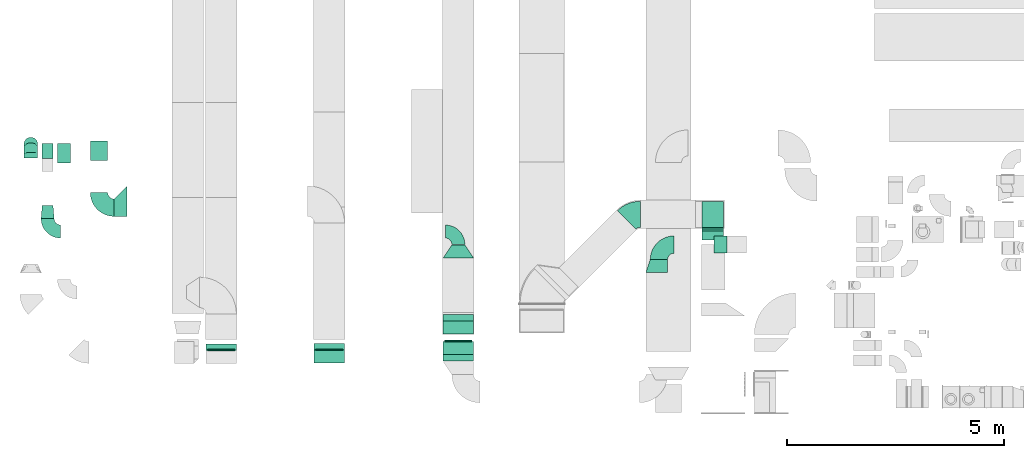
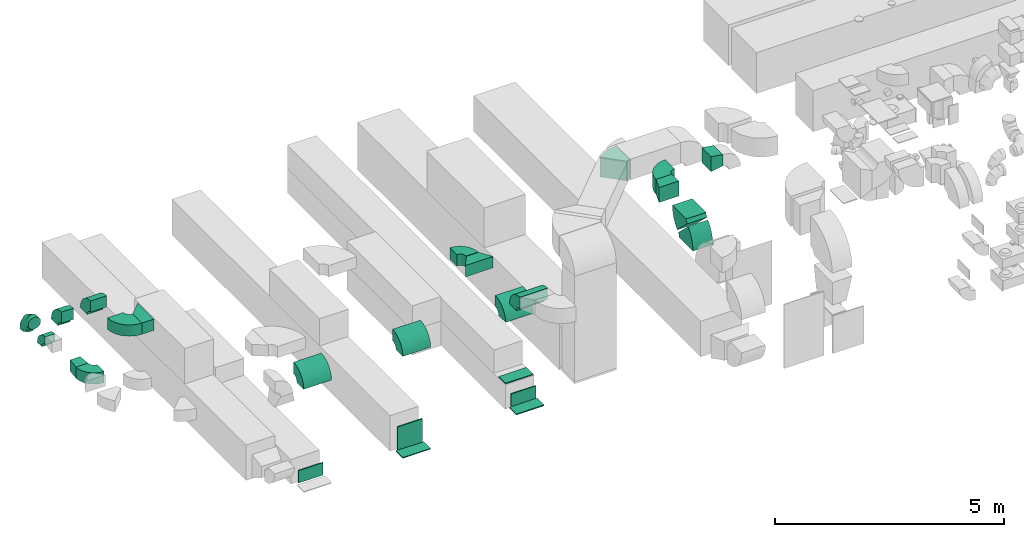
# One storey, part 6 of 59: 26 flow fittings.
"""IFC2X3 building model written with IfcOpenShell, lengths in millimetres."""

import ifcopenshell
import ifcopenshell.guid

model = None  # the IFC model being written
_history = None  # IfcOwnerHistory: only IFC2X3 demands one
_inside = {}  # id of a spatial element -> (the spatial element, [elements in it])
_under = {}  # id of a project, library or spatial element -> (it, [spatial elements below it])
_declared = {}  # id of a project -> (the project, [libraries it declares])
_typed = {}  # id of a type object -> (the type object, [elements of that type])
_made_of = {}  # id of a material, layer set ... -> (it, [elements and type objects made of it])


def new_model(schema):
    """Start an empty IFC model of exactly this schema.

    Asked for "IFC4X3", IfcOpenShell would pick the latest addendum, in which some entities
    have other attributes; the version numbers below select the first issue.
    IFC2X3 requires an IfcOwnerHistory on every rooted entity: one is made here for all.
    """
    global model, _history
    if schema == "IFC4X3":
        model = ifcopenshell.file(schema_version=(4, 3, 0, 0))
    else:
        model = ifcopenshell.file(schema=schema)
    _inside.clear()
    _under.clear()
    _declared.clear()
    _typed.clear()
    _made_of.clear()
    _history = None
    if model.schema == "IFC2X3":
        org = make("IfcOrganization", Name="unknown")
        user = make(
            "IfcPersonAndOrganization",
            ThePerson=make("IfcPerson", FamilyName="unknown"),
            TheOrganization=org,
        )
        app = make(
            "IfcApplication",
            ApplicationDeveloper=org,
            Version="unknown",
            ApplicationFullName="unknown",
            ApplicationIdentifier="unknown",
        )
        _history = make(
            "IfcOwnerHistory",
            OwningUser=user,
            OwningApplication=app,
            ChangeAction="ADDED",
            CreationDate=0,
        )
    return model


def make(cls, **values):
    """One entity of the class cls with the attributes given. An attribute that is None is left unset."""
    return model.create_entity(
        cls, **{name: value for name, value in values.items() if value is not None}
    )


def entity(cls, *values):
    """Any entity or typed value of the class cls, its attributes in the order of the schema. None: left unset."""
    e = model.create_entity(cls)
    for i, value in enumerate(values):
        if value is not None:
            e[i] = value
    return e


def rooted(cls, **values):
    """An entity with a GlobalId (a new one), such as an element, a storey or a relation."""
    return make(cls, GlobalId=ifcopenshell.guid.new(), OwnerHistory=_history, **values)


def si_unit(unit_type, name, prefix=None):
    """IfcSIUnit, for example si_unit("LENGTHUNIT", "METRE", prefix="MILLI")."""
    return make("IfcSIUnit", UnitType=unit_type, Prefix=prefix, Name=name)


def converted_unit(unit_type, name, factor, base, dimensions=None, offset=None):
    """IfcConversionBasedUnit, such as the inch: factor (a typed value) times the base unit."""
    return make(
        "IfcConversionBasedUnit"
        if offset is None
        else "IfcConversionBasedUnitWithOffset",
        ConversionOffset=offset,
        Dimensions=None
        if dimensions is None
        else entity("IfcDimensionalExponents", *dimensions),
        UnitType=unit_type,
        Name=name,
        ConversionFactor=make(
            "IfcMeasureWithUnit", ValueComponent=factor, UnitComponent=base
        ),
    )


def derived_unit(unit_type, elements):
    """IfcDerivedUnit: a product of units, each with its exponent."""
    return make(
        "IfcDerivedUnit",
        Elements=[
            make("IfcDerivedUnitElement", Unit=unit, Exponent=power)
            for unit, power in elements
        ],
        UnitType=unit_type,
    )


def assignment(units):
    """IfcUnitAssignment: the units of a project."""
    return None if units is None else make("IfcUnitAssignment", Units=units)


def point(xyz):
    """IfcCartesianPoint."""
    return None if xyz is None else make("IfcCartesianPoint", Coordinates=xyz)


def direction(xyz):
    """IfcDirection."""
    return None if xyz is None else make("IfcDirection", DirectionRatios=xyz)


def frame(location, z_axis=None, x_axis=None):
    """IfcAxis2Placement3D, a coordinate frame: its origin and axes. An axis left out is left unset."""
    return make(
        "IfcAxis2Placement3D",
        Location=point(location),
        Axis=direction(z_axis),
        RefDirection=direction(x_axis),
    )


def frame_2d(location, x_axis=None):
    """IfcAxis2Placement2D, a coordinate frame in the plane: its origin and x axis."""
    return make(
        "IfcAxis2Placement2D", Location=point(location), RefDirection=direction(x_axis)
    )


def origin():
    """The frame at (0, 0, 0) with its axes left unset."""
    return frame((0.0, 0.0, 0.0))


def origin_2d_with_axis():
    """The frame at (0, 0) in the plane with the x axis (1, 0) written out."""
    return frame_2d((0.0, 0.0), x_axis=(1.0, 0.0))


def place(relative_to, where):
    """IfcLocalPlacement: puts the frame where relative to a parent placement (None: the world)."""
    return make(
        "IfcLocalPlacement", PlacementRelTo=relative_to, RelativePlacement=where
    )


def context(
    kind, dimensions, precision=None, world=None, true_north=None, identifier=None
):
    """IfcGeometricRepresentationContext, for example the 3D "Model" context."""
    return make(
        "IfcGeometricRepresentationContext",
        ContextIdentifier=identifier,
        ContextType=kind,
        CoordinateSpaceDimension=dimensions,
        Precision=precision,
        WorldCoordinateSystem=world,
        TrueNorth=true_north,
    )


def subcontext(parent, identifier, kind, view, scale=None):
    """IfcGeometricRepresentationSubContext, for example "Body" below "Model"."""
    return make(
        "IfcGeometricRepresentationSubContext",
        ContextIdentifier=identifier,
        ContextType=kind,
        ParentContext=parent,
        TargetScale=scale,
        TargetView=view,
    )


def project(units=None, contexts=None):
    """IfcProject with its units and contexts."""
    return rooted(
        "IfcProject",
        Name="project",
        RepresentationContexts=contexts,
        UnitsInContext=assignment(units),
    )


def spatial(cls, under=None, at=None, **own):
    """A site, building, storey or space (cls), placed at a placement, below another one or the project."""
    s = rooted(cls, ObjectPlacement=at, **own)
    if under is not None:
        _under.setdefault(under.id(), (under, []))[1].append(s)
    return s


def polyline(points):
    """IfcPolyline through the points."""
    return make("IfcPolyline", Points=[point(p) for p in points])


def circle_curve(where, radius):
    """IfcCircle in the frame where."""
    return make("IfcCircle", Position=where, Radius=radius)


def parameter(value):
    """IfcParameterValue: where a trimmed curve begins or ends, as a parameter of its basis curve."""
    return model.create_entity("IfcParameterValue", value)


def trimmed(basis, trim1, trim2, sense, master):
    """IfcTrimmedCurve: the piece of a basis curve between two trims."""
    return make(
        "IfcTrimmedCurve",
        BasisCurve=basis,
        Trim1=trim1,
        Trim2=trim2,
        SenseAgreement=sense,
        MasterRepresentation=master,
    )


def segment(curve, same_sense, transition):
    """IfcCompositeCurveSegment."""
    return make(
        "IfcCompositeCurveSegment",
        Transition=transition,
        SameSense=same_sense,
        ParentCurve=curve,
    )


def composite_curve(segments, self_intersect=None):
    """IfcCompositeCurve: segments joined end to end."""
    return make("IfcCompositeCurve", Segments=segments, SelfIntersect=self_intersect)


def profile(cls, at=None, kind="AREA", **sizes):
    """A parametric profile (cls). Its sizes go by their IFC names, for example OverallWidth=200.0."""
    return make(cls, ProfileType=kind, Position=at, **sizes)


def rectangle(**sizes):
    """IfcRectangleProfileDef."""
    return profile("IfcRectangleProfileDef", **sizes)


def outline(outer, holes=None, kind="AREA"):
    """IfcArbitraryClosedProfileDef: a profile drawn as a closed curve; with holes, ...WithVoids."""
    if holes is None:
        return make("IfcArbitraryClosedProfileDef", ProfileType=kind, OuterCurve=outer)
    return make(
        "IfcArbitraryProfileDefWithVoids",
        ProfileType=kind,
        OuterCurve=outer,
        InnerCurves=holes,
    )


def extrude(swept, where, along, depth):
    """IfcExtrudedAreaSolid: the profile swept, set in the frame where, extruded along a direction by depth."""
    return make(
        "IfcExtrudedAreaSolid",
        SweptArea=swept,
        Position=where,
        ExtrudedDirection=direction(along),
        Depth=depth,
    )


def faces_of(points, faces, orient=None, outer=None):
    """IfcFace entities. A face is a list of loops; a loop is a list of indices into points, from 0.

    orient and outer hold one flag for each loop. By default every Orientation is true, the
    first loop of a face is its IfcFaceOuterBound and the others are IfcFaceBound.
    """
    made = []
    for i, loops in enumerate(faces):
        bounds = []
        for j, loop in enumerate(loops):
            is_outer = j == 0 if outer is None else outer[i][j]
            bounds.append(
                make(
                    "IfcFaceOuterBound" if is_outer else "IfcFaceBound",
                    Bound=make("IfcPolyLoop", Polygon=[points[k] for k in loop]),
                    Orientation=True if orient is None else orient[i][j],
                )
            )
        made.append(make("IfcFace", Bounds=bounds))
    return made


def faceted_brep(points, faces, orient=None, outer=None, voids=None):
    """IfcFacetedBrep: a solid bounded by flat faces; with voids (closed shells), ...WithVoids."""
    shared = [point(p) for p in points]
    hull = make("IfcClosedShell", CfsFaces=faces_of(shared, faces, orient, outer))
    if voids is None:
        return make("IfcFacetedBrep", Outer=hull)
    return make(
        "IfcFacetedBrepWithVoids",
        Outer=hull,
        Voids=[
            make(cls, CfsFaces=faces_of(shared, fs, o, b)) for cls, fs, o, b in voids
        ],
    )


def shape(context_of_items, identifier, shape_type, items):
    """IfcShapeRepresentation: the items that make up one representation, for example the "Body"."""
    return make(
        "IfcShapeRepresentation",
        ContextOfItems=context_of_items,
        RepresentationIdentifier=identifier,
        RepresentationType=shape_type,
        Items=items,
    )


def source(mapping_origin, context_of_items, identifier, shape_type, items):
    """IfcRepresentationMap: a shape defined once, which mapped items show again and again."""
    return make(
        "IfcRepresentationMap",
        MappingOrigin=mapping_origin,
        MappedRepresentation=shape(context_of_items, identifier, shape_type, items),
    )


def transform(
    local_origin,
    x_axis=None,
    y_axis=None,
    z_axis=None,
    scale=None,
    scale2=None,
    scale3=None,
    uniform=True,
):
    """IfcCartesianTransformationOperator3D, or its non-uniform kind. x_axis, y_axis, z_axis: its Axis1, 2, 3."""
    if uniform:
        return make(
            "IfcCartesianTransformationOperator3D",
            Axis1=direction(x_axis),
            Axis2=direction(y_axis),
            LocalOrigin=point(local_origin),
            Scale=scale,
            Axis3=direction(z_axis),
        )
    return make(
        "IfcCartesianTransformationOperator3DnonUniform",
        Axis1=direction(x_axis),
        Axis2=direction(y_axis),
        LocalOrigin=point(local_origin),
        Scale=scale,
        Axis3=direction(z_axis),
        Scale2=scale2,
        Scale3=scale3,
    )


def mapped(mapping_source, mapping_target):
    """IfcMappedItem: shows the shape of a source again, moved by a transform."""
    return make(
        "IfcMappedItem", MappingSource=mapping_source, MappingTarget=mapping_target
    )


def material(Name=None, Category=None):
    """IfcMaterial."""
    return make("IfcMaterial", Name=Name, Category=Category)


def made_of(thing, what):
    """Note that an element or type object is made of a material, layer set ...; save() writes the relation."""
    if what is not None:
        _made_of.setdefault(what.id(), (what, []))[1].append(thing)
    return thing


def type_object(cls, material=None, **own):
    """A type object (cls), such as IfcWallType, which elements share."""
    return made_of(rooted(cls, **own), material)


def type_shapes(of_type, sources):
    """Give a type object the sources (RepresentationMaps) that its elements show as mapped items."""
    of_type.RepresentationMaps = sources


def element(
    cls,
    number,
    at=None,
    inside=None,
    cuts=None,
    type_object=None,
    material=None,
    context=None,
    identifier="Body",
    shape_type=None,
    held_by="IfcProductDefinitionShape",
    body=None,
    shapes=None,
    **own,
):
    """One element of the class cls, such as IfcWall. Its Tag is "e" and its number.

    at: its placement. inside: the storey or other place that contains it. cuts: it is an
    opening in that element (IfcRelVoidsElement). A single representation is given by context,
    identifier, shape_type and body (its items); several are given by shapes. held_by: the class
    of the entity that holds the representations. save() writes the other relations.
    """
    e = rooted(cls, Tag="e%d" % number, ObjectPlacement=at, **own)
    if body is not None:
        shapes = [shape(context, identifier, shape_type, body)]
    if shapes is not None:
        e.Representation = make(held_by, Representations=shapes)
    if inside is not None:
        _inside.setdefault(inside.id(), (inside, []))[1].append(e)
    if cuts is not None:
        rooted(
            "IfcRelVoidsElement", RelatingBuildingElement=cuts, RelatedOpeningElement=e
        )
    if type_object is not None:
        _typed.setdefault(type_object.id(), (type_object, []))[1].append(e)
    return made_of(e, material)


def aggregate(whole, parts):
    """IfcRelAggregates: a whole, such as a stair, and the parts it consists of."""
    return rooted("IfcRelAggregates", RelatingObject=whole, RelatedObjects=parts)


def save(model, path):
    """Write the relations noted so far, then the file.

    IfcRelAggregates (storeys below a building ...), IfcRelContainedInSpatialStructure (elements
    in a storey), IfcRelDefinesByType, IfcRelAssociatesMaterial and IfcRelDeclares: one each for
    every whole, place, type object, material and project.
    """
    for whole, parts in _under.values():
        aggregate(whole, parts)
    for where, things in _inside.values():
        rooted(
            "IfcRelContainedInSpatialStructure",
            RelatedElements=things,
            RelatingStructure=where,
        )
    for kind, things in _typed.values():
        rooted("IfcRelDefinesByType", RelatedObjects=things, RelatingType=kind)
    for what, things in _made_of.values():
        rooted("IfcRelAssociatesMaterial", RelatedObjects=things, RelatingMaterial=what)
    for by, libraries in _declared.values():
        rooted("IfcRelDeclares", RelatingContext=by, RelatedDefinitions=libraries)
    model.write(path)


model = new_model("IFC2X3")

# Units and contexts
model_context = context("Model", 3, precision=0.01, world=origin(), true_north=direction((6.12303176911189e-17, 1.0)))
body_context = subcontext(model_context, "Body", "Model", "MODEL_VIEW")
ifc_project = project(units=[si_unit("LENGTHUNIT", "METRE", prefix="MILLI"), si_unit("AREAUNIT", "SQUARE_METRE"), si_unit("VOLUMEUNIT", "CUBIC_METRE"), converted_unit("PLANEANGLEUNIT", "DEGREE", entity("IfcRatioMeasure", 0.0174532925199433), si_unit("PLANEANGLEUNIT", "RADIAN"), dimensions=[0, 0, 0, 0, 0, 0, 0]), si_unit("MASSUNIT", "GRAM", prefix="KILO"), derived_unit("MASSDENSITYUNIT", [(si_unit("MASSUNIT", "GRAM", prefix="KILO"), 1), (si_unit("LENGTHUNIT", "METRE"), -3)]), derived_unit("MOMENTOFINERTIAUNIT", [(si_unit("LENGTHUNIT", "METRE"), 4)]), si_unit("TIMEUNIT", "SECOND"), si_unit("FREQUENCYUNIT", "HERTZ"), si_unit("THERMODYNAMICTEMPERATUREUNIT", "DEGREE_CELSIUS"), derived_unit("THERMALTRANSMITTANCEUNIT", [(si_unit("MASSUNIT", "GRAM", prefix="KILO"), 1), (si_unit("THERMODYNAMICTEMPERATUREUNIT", "KELVIN"), -1), (si_unit("TIMEUNIT", "SECOND"), -3)]), derived_unit("VOLUMETRICFLOWRATEUNIT", [(si_unit("LENGTHUNIT", "METRE"), 3), (si_unit("TIMEUNIT", "SECOND"), -1)]), derived_unit("MASSFLOWRATEUNIT", [(si_unit("MASSUNIT", "GRAM", prefix="KILO"), 1), (si_unit("TIMEUNIT", "SECOND"), -1)]), derived_unit("ROTATIONALFREQUENCYUNIT", [(si_unit("TIMEUNIT", "SECOND"), -1)]), si_unit("ELECTRICCURRENTUNIT", "AMPERE"), si_unit("ELECTRICVOLTAGEUNIT", "VOLT"), si_unit("POWERUNIT", "WATT"), si_unit("FORCEUNIT", "NEWTON", prefix="KILO"), si_unit("ILLUMINANCEUNIT", "LUX"), si_unit("LUMINOUSFLUXUNIT", "LUMEN"), si_unit("LUMINOUSINTENSITYUNIT", "CANDELA"), derived_unit("USERDEFINED", [(si_unit("MASSUNIT", "GRAM", prefix="KILO"), -1), (si_unit("LENGTHUNIT", "METRE"), -2), (si_unit("TIMEUNIT", "SECOND"), 3), (si_unit("LUMINOUSFLUXUNIT", "LUMEN"), 1)]), derived_unit("LINEARVELOCITYUNIT", [(si_unit("LENGTHUNIT", "METRE"), 1), (si_unit("TIMEUNIT", "SECOND"), -1)]), si_unit("PRESSUREUNIT", "PASCAL"), derived_unit("USERDEFINED", [(si_unit("LENGTHUNIT", "METRE"), -2), (si_unit("MASSUNIT", "GRAM", prefix="KILO"), 1), (si_unit("TIMEUNIT", "SECOND"), -2)]), derived_unit("LINEARFORCEUNIT", [(si_unit("MASSUNIT", "GRAM", prefix="KILO"), 1), (si_unit("LENGTHUNIT", "METRE"), 1), (si_unit("TIMEUNIT", "SECOND"), -2), (si_unit("LENGTHUNIT", "METRE"), -1)]), derived_unit("PLANARFORCEUNIT", [(si_unit("MASSUNIT", "GRAM", prefix="KILO"), 1), (si_unit("LENGTHUNIT", "METRE"), 1), (si_unit("TIMEUNIT", "SECOND"), -2), (si_unit("LENGTHUNIT", "METRE"), -2)])], contexts=[model_context])

# Site, building, storey
site_placement = place(None, origin())
site = spatial("IfcSite", under=ifc_project, at=site_placement, CompositionType="ELEMENT")
building_placement = place(site_placement, origin())
building = spatial("IfcBuilding", under=site, at=building_placement, CompositionType="ELEMENT")
storey_placement = place(building_placement, frame((0.0, 0.0, 28200.0)))
storey = spatial("IfcBuildingStorey", under=building, at=storey_placement, CompositionType="ELEMENT", Elevation=28200.0)

# Flow fittings
ifc_material = material()
duct_fitting_type_1 = type_object("IfcDuctFittingType", PredefinedType="NOTDEFINED", material=ifc_material)
shared_shape_1 = source(origin(), body_context, "Body", "SweptSolid", [
    extrude(outline(polyline([(-180.84, -172.62), (123.3, -172.62), (172.62, 123.3), (-115.08, 221.94), (-180.84, -172.62)])), frame((150.0, -200.0, 0.0), z_axis=(0.0, 1.0, 0.0), x_axis=(0.986393923832128, 0.0, -0.16439898730545)), (0.0, 0.0, 1.0), 400.0),
])
type_shapes(duct_fitting_type_1, [shared_shape_1])
flow_fitting_1_placement = place(storey_placement, frame((24358.28, 11698.95, 3350.0)))
element("IfcFlowFitting", 1, at=flow_fitting_1_placement, inside=storey, type_object=duct_fitting_type_1, material=ifc_material, context=body_context, shape_type="MappedRepresentation", body=[
    mapped(shared_shape_1, transform((0.0, 0.0, 0.0), scale=1.0)),
])
duct_fitting_type_2 = type_object("IfcDuctFittingType", PredefinedType="NOTDEFINED", material=ifc_material)
shared_shape_2 = source(origin(), body_context, "Body", "SweptSolid", [
    extrude(outline(polyline([(-406.59, -194.45), (17.68, -194.45), (300.52, 88.39), (88.39, 300.52), (-406.59, -194.45)])), frame((150.0, 75.0, -150.0), z_axis=(0.0, 0.0, 1.0), x_axis=(0.70710678118654, 0.707106781186555, 0.0)), (0.0, 0.0, 1.0), 300.0),
])
type_shapes(duct_fitting_type_2, [shared_shape_2])
flow_fitting_2_placement = place(storey_placement, frame((10823.95, 12699.6, 3300.0), z_axis=(0.0, 0.0, 1.0), x_axis=(-1.0, 0.0, 0.0)))
element("IfcFlowFitting", 2, at=flow_fitting_2_placement, inside=storey, type_object=duct_fitting_type_2, material=ifc_material, context=body_context, shape_type="MappedRepresentation", body=[
    mapped(shared_shape_2, transform((0.0, 0.0, 0.0), scale=1.0)),
])
duct_fitting_type_3 = type_object("IfcDuctFittingType", PredefinedType="NOTDEFINED", material=ifc_material)
shared_shape_3 = source(origin(), body_context, "Body", "SweptSolid", [
    extrude(outline(polyline([(-318.95, -208.01), (41.6, -208.01), (208.01, 41.6), (69.34, 374.42), (-318.95, -208.01)])), frame((150.0, 0.0, -150.0), z_axis=(0.0, 0.0, 1.0), x_axis=(0.832050294337844, 0.554700196225228, 0.0)), (0.0, 0.0, 1.0), 300.0),
])
type_shapes(duct_fitting_type_3, [shared_shape_3])
flow_fitting_3_placement = place(storey_placement, frame((18464.38, 11392.52, 2750.0), z_axis=(0.0, 0.0, 1.0), x_axis=(0.0, 1.0, 0.0)))
element("IfcFlowFitting", 3, at=flow_fitting_3_placement, inside=storey, type_object=duct_fitting_type_3, material=ifc_material, context=body_context, shape_type="MappedRepresentation", body=[
    mapped(shared_shape_3, transform((0.0, 0.0, 0.0), scale=1.0)),
])
duct_fitting_type_4 = type_object("IfcDuctFittingType", PredefinedType="NOTDEFINED", material=ifc_material)
shared_shape_4 = source(origin(), body_context, "Body", "SweptSolid", [
    extrude(outline(polyline([(-161.94, -137.03), (139.1, -137.03), (159.86, 112.11), (-137.03, 161.94), (-161.94, -137.03)])), frame((150.0, 0.0, -150.0), z_axis=(0.0, 0.0, 1.0), x_axis=(0.99654575824488, 0.0830454798537381, 0.0)), (0.0, 0.0, 1.0), 300.0),
])
type_shapes(duct_fitting_type_4, [shared_shape_4])
flow_fitting_4_placement = place(storey_placement, frame((8988.91, 12299.6, 2750.0), z_axis=(0.0, 0.0, 1.0), x_axis=(0.0, 1.0, 0.0)))
element("IfcFlowFitting", 4, at=flow_fitting_4_placement, inside=storey, type_object=duct_fitting_type_4, material=ifc_material, context=body_context, shape_type="MappedRepresentation", body=[
    mapped(shared_shape_4, transform((0.0, 0.0, 0.0), scale=1.0)),
])
duct_fitting_type_5 = type_object("IfcDuctFittingType", PredefinedType="NOTDEFINED", material=ifc_material)
shared_shape_5 = source(origin(), body_context, "Body", "SweptSolid", [
    extrude(outline(polyline([(-150.0, -225.0), (150.0, -225.0), (150.0, 175.0), (-150.0, 275.0), (-150.0, -225.0)])), frame((150.0, -25.0, -200.0)), (0.0, 0.0, 1.0), 400.0),
])
type_shapes(duct_fitting_type_5, [shared_shape_5])
flow_fitting_5_placement = place(storey_placement, frame((23040.03, 11048.95, 3350.0), z_axis=(0.0, 0.0, 1.0), x_axis=(0.0, 1.0, 0.0)))
element("IfcFlowFitting", 5, at=flow_fitting_5_placement, inside=storey, type_object=duct_fitting_type_5, material=ifc_material, context=body_context, shape_type="MappedRepresentation", body=[
    mapped(shared_shape_5, transform((0.0, 0.0, 0.0), scale=1.0)),
])
duct_fitting_type_6 = type_object("IfcDuctFittingType", PredefinedType="NOTDEFINED", material=ifc_material)
shared_shape_6 = source(origin(), body_context, "Body", "SweptSolid", [
    extrude(rectangle(XDim=24.9999999999999, YDim=700.0, at=origin_2d_with_axis()), frame((12.5, 0.0, -150.0)), (0.0, 0.0, 1.0), 300.0),
])
type_shapes(duct_fitting_type_6, [shared_shape_6])
for number, where, z_axis, x_axis in (
    (6, (18464.38, 9316.27, 300.0), (0.0, -1.0, 0.0), (0.0, 0.0, -1.0)),
    (7, (18464.38, 9788.14, 833.96), (0.0, -1.0, 0.0), (0.0, 0.0, -1.0)),
):
    element("IfcFlowFitting", number, at=place(storey_placement, frame(where, z_axis=z_axis, x_axis=x_axis)), inside=storey, type_object=duct_fitting_type_6, material=ifc_material, context=body_context, shape_type="MappedRepresentation", body=[
        mapped(shared_shape_6, transform((0.0, 0.0, 0.0), scale=1.0)),
    ])
duct_fitting_type_7 = type_object("IfcDuctFittingType", PredefinedType="NOTDEFINED", material=ifc_material)
shared_shape_7 = source(origin(), body_context, "Body", "SweptSolid", [
    extrude(rectangle(XDim=24.9999999999999, YDim=300.0, at=origin_2d_with_axis()), frame((12.5, 0.0, -350.0)), (0.0, 0.0, 1.0), 700.0),
])
type_shapes(duct_fitting_type_7, [shared_shape_7])
flow_fitting_6_placement = place(storey_placement, frame((15487.92, 9111.6, 310.0), z_axis=(1.0, 0.0, 0.0), x_axis=(0.0, 0.0, -1.0)))
element("IfcFlowFitting", 8, at=flow_fitting_6_placement, inside=storey, type_object=duct_fitting_type_7, material=ifc_material, context=body_context, shape_type="MappedRepresentation", body=[
    mapped(shared_shape_7, transform((0.0, 0.0, 0.0), scale=1.0)),
])
duct_fitting_type_8 = type_object("IfcDuctFittingType", PredefinedType="NOTDEFINED", material=ifc_material)
shared_shape_8 = source(origin(), body_context, "Body", "SweptSolid", [
    extrude(rectangle(XDim=26.0960000000092, YDim=330.0, at=origin_2d_with_axis()), frame((6.95, 0.0, -310.0)), (0.0, 0.0, 1.0), 620.0),
])
type_shapes(duct_fitting_type_8, [shared_shape_8])
flow_fitting_7_placement = place(storey_placement, frame((18464.38, 9466.27, 477.0), z_axis=(1.0, 0.0, 0.0), x_axis=(0.0, 1.0, 0.0)))
element("IfcFlowFitting", 9, at=flow_fitting_7_placement, inside=storey, type_object=duct_fitting_type_8, material=ifc_material, context=body_context, shape_type="MappedRepresentation", body=[
    mapped(shared_shape_8, transform((0.0, 0.0, 0.0), scale=1.0)),
])
duct_fitting_type_9 = type_object("IfcDuctFittingType", PredefinedType="NOTDEFINED", material=ifc_material)
shared_shape_9 = source(origin(), body_context, "Body", "SweptSolid", [
    extrude(rectangle(XDim=26.0960000000031, YDim=620.0, at=origin_2d_with_axis()), frame((6.95, 0.0, -310.0)), (0.0, 0.0, 1.0), 620.0),
])
type_shapes(duct_fitting_type_9, [shared_shape_9])
flow_fitting_8_placement = place(storey_placement, frame((15487.92, 9261.6, 622.0), z_axis=(1.0, 0.0, 0.0), x_axis=(0.0, 1.0, 0.0)))
element("IfcFlowFitting", 10, at=flow_fitting_8_placement, inside=storey, type_object=duct_fitting_type_9, material=ifc_material, context=body_context, shape_type="MappedRepresentation", body=[
    mapped(shared_shape_9, transform((0.0, 0.0, 0.0), scale=1.0)),
])
duct_fitting_type_10 = type_object("IfcDuctFittingType", PredefinedType="NOTDEFINED", material=ifc_material)
shared_shape_10 = source(origin(), body_context, "Body", "SweptSolid", [
    extrude(rectangle(XDim=330.0, YDim=26.0960000000108, at=origin_2d_with_axis()), frame((6.95, 0.0, -310.0), z_axis=(0.0, 0.0, 1.0), x_axis=(0.0, -1.0, 0.0)), (0.0, 0.0, 1.0), 620.0),
])
type_shapes(duct_fitting_type_10, [shared_shape_10])
flow_fitting_9_placement = place(storey_placement, frame((12992.68, 9259.6, 477.0), z_axis=(1.0, 0.0, 0.0), x_axis=(0.0, 1.0, 0.0)))
element("IfcFlowFitting", 11, at=flow_fitting_9_placement, inside=storey, type_object=duct_fitting_type_10, material=ifc_material, context=body_context, shape_type="MappedRepresentation", body=[
    mapped(shared_shape_10, transform((0.0, 0.0, 0.0), scale=1.0)),
])
duct_fitting_type_11 = type_object("IfcDuctFittingType", PredefinedType="NOTDEFINED", material=ifc_material)
shared_shape_11 = source(origin(), body_context, "Body", "Brep", [
    faceted_brep([(-315.0, 0.0, -157.5), (-315.0, -40.76, -152.13), (-315.0, -78.75, -136.4), (-315.0, -111.37, -111.37), (-315.0, -136.4, -78.75), (-315.0, -152.13, -40.76), (-315.0, -157.5, 0.0), (-315.0, -152.13, 40.76), (-315.0, -136.4, 78.75), (-315.0, -111.37, 111.37), (-315.0, -78.75, 136.4), (-315.0, -40.76, 152.13), (-315.0, 0.0, 157.5), (-315.0, 40.76, 152.13), (-315.0, 78.75, 136.4), (-315.0, 111.37, 111.37), (-315.0, 136.4, 78.75), (-315.0, 152.13, 40.76), (-315.0, 157.5, 0.0), (-315.0, 152.13, -40.76), (-315.0, 136.4, -78.75), (-315.0, 111.37, -111.37), (-315.0, 78.75, -136.4), (-315.0, 40.76, -152.13), (-241.52, 40.76, 152.13), (-251.7, 78.75, 136.4), (-230.6, 0.0, 157.5), (-260.44, 111.37, 111.37), (-271.36, 152.13, 40.76), (-272.8, 157.5, 0.0), (-267.14, 136.4, 78.75), (-267.14, 136.4, -78.75), (-260.44, 111.37, -111.37), (-271.36, 152.13, -40.76), (-241.52, 40.76, -152.13), (-230.6, 0.0, -157.5), (-251.7, 78.75, -136.4), (-219.67, -40.76, -152.13), (-209.5, -78.75, -136.4), (-200.75, -111.37, -111.37), (-194.05, -136.4, -78.75), (-189.83, -152.13, -40.76), (-188.39, -157.5, 0.0), (-189.83, -152.13, 40.76), (-194.05, -136.4, 78.75), (-200.75, -111.37, 111.37), (-209.5, -78.75, 136.4), (-219.67, -40.76, 152.13), (-114.25, 114.25, 152.13), (-142.05, 142.05, 136.4), (-84.4, 84.4, 157.5), (-165.93, 165.93, 111.37), (-184.25, 184.25, 78.75), (-195.77, 195.77, 40.76), (-199.7, 199.7, 0.0), (-195.77, 195.77, -40.76), (-184.25, 184.25, -78.75), (-165.93, 165.93, -111.37), (-114.25, 114.25, -152.13), (-84.4, 84.4, -157.5), (-142.05, 142.05, -136.4), (-54.56, 54.56, -152.13), (-26.75, 26.75, -136.4), (-2.88, 2.88, -111.37), (15.45, -15.45, -78.75), (26.97, -26.97, -40.76), (30.89, -30.89, 0.0), (26.97, -26.97, 40.76), (15.45, -15.45, 78.75), (-2.88, 2.88, 111.37), (-26.75, 26.75, 136.4), (-54.56, 54.56, 152.13), (-40.76, 241.52, 152.13), (-78.75, 251.7, 136.4), (0.0, 230.6, 157.5), (-111.37, 260.44, 111.37), (-136.4, 267.14, 78.75), (-152.13, 271.36, 40.76), (-157.5, 272.8, 0.0), (-152.13, 271.36, -40.76), (-136.4, 267.14, -78.75), (-111.37, 260.44, -111.37), (-40.76, 241.52, -152.13), (0.0, 230.6, -157.5), (-78.75, 251.7, -136.4), (40.76, 219.67, -152.13), (78.75, 209.5, -136.4), (111.37, 200.75, -111.37), (136.4, 194.05, -78.75), (152.13, 189.83, -40.76), (157.5, 188.39, 0.0), (152.13, 189.83, 40.76), (136.4, 194.05, 78.75), (111.37, 200.75, 111.37), (78.75, 209.5, 136.4), (40.76, 219.67, 152.13), (-40.76, 315.0, -152.13), (-78.75, 315.0, -136.4), (-111.37, 315.0, -111.37), (-136.4, 315.0, -78.75), (-152.13, 315.0, -40.76), (-157.5, 315.0, 0.0), (-152.13, 315.0, 40.76), (-136.4, 315.0, 78.75), (-111.37, 315.0, 111.37), (-78.75, 315.0, 136.4), (-40.76, 315.0, 152.13), (0.0, 315.0, 157.5), (40.76, 315.0, 152.13), (78.75, 315.0, 136.4), (111.37, 315.0, 111.37), (136.4, 315.0, 78.75), (152.13, 315.0, 40.76), (157.5, 315.0, 0.0), (152.13, 315.0, -40.76), (136.4, 315.0, -78.75), (111.37, 315.0, -111.37), (78.75, 315.0, -136.4), (40.76, 315.0, -152.13), (0.0, 315.0, -157.5)], [[[0, 1, 2, 3, 4, 5, 6, 7, 8, 9, 10, 11, 12, 13, 14, 15, 16, 17, 18, 19, 20, 21, 22, 23]], [[24, 25, 14, 13]], [[26, 24, 13, 12]], [[14, 25, 27, 15]], [[28, 29, 18, 17]], [[30, 28, 17, 16]], [[15, 27, 30, 16]], [[20, 31, 32, 21]], [[33, 31, 20, 19]], [[18, 29, 33, 19]], [[34, 35, 0, 23]], [[36, 34, 23, 22]], [[32, 36, 22, 21]], [[1, 0, 35, 37]], [[2, 1, 37, 38]], [[38, 39, 3, 2]], [[5, 4, 40, 41]], [[6, 5, 41, 42]], [[39, 40, 4, 3]], [[6, 42, 43, 7]], [[7, 43, 44, 8]], [[8, 44, 45, 9]], [[9, 45, 46, 10]], [[10, 46, 47, 11]], [[26, 12, 11, 47]], [[48, 49, 25, 24]], [[50, 48, 24, 26]], [[27, 25, 49, 51]], [[52, 53, 28, 30]], [[51, 52, 30, 27]], [[29, 28, 53, 54]], [[55, 56, 31, 33]], [[54, 55, 33, 29]], [[32, 31, 56, 57]], [[58, 59, 35, 34]], [[60, 58, 34, 36]], [[57, 60, 36, 32]], [[37, 35, 59, 61]], [[38, 37, 61, 62]], [[39, 38, 62, 63]], [[41, 40, 64, 65]], [[42, 41, 65, 66]], [[63, 64, 40, 39]], [[43, 42, 66, 67]], [[44, 43, 67, 68]], [[68, 69, 45, 44]], [[46, 45, 69, 70]], [[47, 46, 70, 71]], [[26, 47, 71, 50]], [[72, 73, 49, 48]], [[74, 72, 48, 50]], [[51, 49, 73, 75]], [[76, 77, 53, 52]], [[75, 76, 52, 51]], [[54, 53, 77, 78]], [[79, 80, 56, 55]], [[78, 79, 55, 54]], [[57, 56, 80, 81]], [[82, 83, 59, 58]], [[84, 82, 58, 60]], [[81, 84, 60, 57]], [[61, 59, 83, 85]], [[62, 61, 85, 86]], [[63, 62, 86, 87]], [[65, 64, 88, 89]], [[66, 65, 89, 90]], [[87, 88, 64, 63]], [[67, 66, 90, 91]], [[68, 67, 91, 92]], [[92, 93, 69, 68]], [[70, 69, 93, 94]], [[71, 70, 94, 95]], [[50, 71, 95, 74]], [[96, 97, 98, 99, 100, 101, 102, 103, 104, 105, 106, 107, 108, 109, 110, 111, 112, 113, 114, 115, 116, 117, 118, 119]], [[106, 105, 73, 72]], [[107, 106, 72, 74]], [[75, 73, 105, 104]], [[77, 76, 103, 102]], [[78, 77, 102, 101]], [[104, 103, 76, 75]], [[78, 101, 100, 79]], [[79, 100, 99, 80]], [[98, 81, 80, 99]], [[84, 97, 96, 82]], [[82, 96, 119, 83]], [[97, 84, 81, 98]], [[83, 119, 118, 85]], [[85, 118, 117, 86]], [[116, 87, 86, 117]], [[88, 115, 114, 89]], [[89, 114, 113, 90]], [[115, 88, 87, 116]], [[91, 90, 113, 112]], [[92, 91, 112, 111]], [[111, 110, 93, 92]], [[95, 94, 109, 108]], [[74, 95, 108, 107]], [[110, 109, 94, 93]]]),
])
type_shapes(duct_fitting_type_11, [shared_shape_11])
flow_fitting_10_placement = place(storey_placement, frame((8601.41, 14016.72, 3300.0), z_axis=(-1.0, 0.0, 0.0), x_axis=(0.0, 1.0, 0.0)))
element("IfcFlowFitting", 12, at=flow_fitting_10_placement, inside=storey, type_object=duct_fitting_type_11, material=ifc_material, context=body_context, shape_type="MappedRepresentation", body=[
    mapped(shared_shape_11, transform((0.0, 0.0, 0.0), scale=1.0)),
])
duct_fitting_type_12 = type_object("IfcDuctFittingType", PredefinedType="NOTDEFINED", material=ifc_material)
shared_shape_12 = source(origin(), body_context, "Body", "SweptSolid", [
    extrude(outline(composite_curve([segment(polyline([(-300.0, -150.0), (0.0, -150.0)]), True, "CONTINUOUS"), segment(trimmed(circle_curve(frame_2d((150.0, -150.0), x_axis=(0.0, 1.0)), 150.0), [parameter(0.0)], [parameter(90.0)], True, "PARAMETER"), False, "CONTINUOUS"), segment(polyline([(150.0, 0.0), (150.0, 300.0)]), True, "CONTINUOUS"), segment(trimmed(circle_curve(frame_2d((150.0, -150.0), x_axis=(0.0, 1.0)), 450.0), [parameter(0.0)], [parameter(90.0000000000001)], True, "PARAMETER"), True, "CONTINUOUS")], self_intersect=False)), frame((-150.0, 150.0, -150.0), z_axis=(0.0, 0.0, 1.0), x_axis=(-1.0, 0.0, 0.0)), (0.0, 0.0, 1.0), 300.0),
])
type_shapes(duct_fitting_type_12, [shared_shape_12])
for number, where, z_axis, x_axis in (
    (13, (18464.38, 11999.6, 2750.0), (0.0, 0.0, 1.0), (0.0, 1.0, 0.0)),
    (14, (8988.91, 11999.6, 2750.0), (0.0, 0.0, 1.0), (0.0, -1.0, 0.0)),
    (15, (9364.47, 13884.03, 3300.0), (-1.0, 0.0, 0.0), (0.0, 1.0, 0.0)),
):
    element("IfcFlowFitting", number, at=place(storey_placement, frame(where, z_axis=z_axis, x_axis=x_axis)), inside=storey, type_object=duct_fitting_type_12, material=ifc_material, context=body_context, shape_type="MappedRepresentation", body=[
        mapped(shared_shape_12, transform((0.0, 0.0, 0.0), scale=1.0)),
    ])
duct_fitting_type_13 = type_object("IfcDuctFittingType", PredefinedType="NOTDEFINED", material=ifc_material)
shared_shape_13 = source(origin(), body_context, "Body", "SweptSolid", [
    extrude(outline(composite_curve([segment(polyline([(-225.0, -125.0), (-25.0, -125.0)]), True, "CONTINUOUS"), segment(trimmed(circle_curve(frame_2d((125.0, -125.0), x_axis=(0.0, 1.0)), 150.0), [parameter(0.0)], [parameter(90.0)], True, "PARAMETER"), False, "CONTINUOUS"), segment(polyline([(125.0, 25.0), (125.0, 225.0)]), True, "CONTINUOUS"), segment(trimmed(circle_curve(frame_2d((125.0, -125.0), x_axis=(0.0, 1.0)), 350.0), [parameter(0.0)], [parameter(90.0)], True, "PARAMETER"), True, "CONTINUOUS")], self_intersect=False)), frame((-125.0, 125.0, -125.0), z_axis=(0.0, 0.0, 1.0), x_axis=(-1.0, 0.0, 0.0)), (0.0, 0.0, 1.0), 250.0),
])
type_shapes(duct_fitting_type_13, [shared_shape_13])
flow_fitting_11_placement = place(storey_placement, frame((8987.33, 13933.89, 2750.0), z_axis=(-0.999996527502329, 0.0, -0.00263533361906666), x_axis=(0.0, 1.0, 0.0)))
element("IfcFlowFitting", 16, at=flow_fitting_11_placement, inside=storey, type_object=duct_fitting_type_13, material=ifc_material, context=body_context, shape_type="MappedRepresentation", body=[
    mapped(shared_shape_13, transform((0.0, 0.0, 0.0), scale=1.0)),
])
duct_fitting_type_14 = type_object("IfcDuctFittingType", PredefinedType="NOTDEFINED", material=ifc_material)
shared_shape_14 = source(origin(), body_context, "Body", "SweptSolid", [
    extrude(outline(composite_curve([segment(polyline([(-375.0, -175.0), (25.0, -175.0)]), True, "CONTINUOUS"), segment(trimmed(circle_curve(frame_2d((175.0, -175.0), x_axis=(0.0, 1.0)), 150.0), [parameter(0.0)], [parameter(90.0000000000001)], True, "PARAMETER"), False, "CONTINUOUS"), segment(polyline([(175.0, -25.0), (175.0, 375.0)]), True, "CONTINUOUS"), segment(trimmed(circle_curve(frame_2d((175.0, -175.0), x_axis=(0.0, 1.0)), 550.0), [parameter(0.0)], [parameter(90.0)], True, "PARAMETER"), True, "CONTINUOUS")], self_intersect=False)), frame((-175.0, 175.0, -150.0), z_axis=(0.0, 0.0, 1.0), x_axis=(-1.0, 0.0, 0.0)), (0.0, 0.0, 1.0), 300.0),
])
type_shapes(duct_fitting_type_14, [shared_shape_14])
flow_fitting_12_placement = place(storey_placement, frame((10173.95, 12549.6, 3300.0), z_axis=(0.0, 0.0, 1.0), x_axis=(0.0, -1.0, 0.0)))
element("IfcFlowFitting", 17, at=flow_fitting_12_placement, inside=storey, type_object=duct_fitting_type_14, material=ifc_material, context=body_context, shape_type="MappedRepresentation", body=[
    mapped(shared_shape_14, transform((0.0, 0.0, 0.0), scale=1.0)),
])
duct_fitting_type_15 = type_object("IfcDuctFittingType", PredefinedType="NOTDEFINED", material=ifc_material)
shared_shape_15 = source(origin(), body_context, "Body", "SweptSolid", [
    extrude(outline(composite_curve([segment(polyline([(-375.0, -175.0), (25.0, -175.0)]), True, "CONTINUOUS"), segment(trimmed(circle_curve(frame_2d((175.0, -175.0), x_axis=(0.0, 1.0)), 150.0), [parameter(0.0)], [parameter(90.0)], True, "PARAMETER"), False, "CONTINUOUS"), segment(polyline([(175.0, -25.0), (175.0, 375.0)]), True, "CONTINUOUS"), segment(trimmed(circle_curve(frame_2d((175.0, -175.0), x_axis=(0.0, 1.0)), 550.0), [parameter(0.0)], [parameter(90.0)], True, "PARAMETER"), True, "CONTINUOUS")], self_intersect=False)), frame((-175.0, 175.0, -200.0), z_axis=(0.0, 0.0, 1.0), x_axis=(-1.0, 0.0, 0.0)), (0.0, 0.0, 1.0), 400.0),
])
type_shapes(duct_fitting_type_15, [shared_shape_15])
flow_fitting_13_placement = place(storey_placement, frame((23090.03, 11698.95, 3350.0), z_axis=(0.0, 0.0, 1.0), x_axis=(-1.0, 0.0, 0.0)))
element("IfcFlowFitting", 18, at=flow_fitting_13_placement, inside=storey, type_object=duct_fitting_type_15, material=ifc_material, context=body_context, shape_type="MappedRepresentation", body=[
    mapped(shared_shape_15, transform((0.0, 0.0, 0.0), scale=1.0)),
])
duct_fitting_type_16 = type_object("IfcDuctFittingType", PredefinedType="NOTDEFINED", material=ifc_material)
shared_shape_16 = source(origin(), body_context, "Body", "SweptSolid", [
    extrude(outline(composite_curve([segment(polyline([(-300.0, -150.0), (0.0, -150.0)]), True, "CONTINUOUS"), segment(trimmed(circle_curve(frame_2d((150.0, -150.0), x_axis=(0.0, 1.0)), 150.0), [parameter(0.0)], [parameter(90.0)], True, "PARAMETER"), False, "CONTINUOUS"), segment(polyline([(150.0, 0.0), (150.0, 300.0)]), True, "CONTINUOUS"), segment(trimmed(circle_curve(frame_2d((150.0, -150.0), x_axis=(0.0, 1.0)), 450.0), [parameter(0.0)], [parameter(90.0000000000001)], True, "PARAMETER"), True, "CONTINUOUS")], self_intersect=False)), frame((-150.0, 150.0, -350.0), z_axis=(0.0, 0.0, 1.0), x_axis=(-1.0, 0.0, 0.0)), (0.0, 0.0, 1.0), 700.0),
])
type_shapes(duct_fitting_type_16, [shared_shape_16])
for number, where, z_axis, x_axis in (
    (19, (15487.92, 9111.6, 3300.0), (-1.0, 0.0, 0.0), (0.0, 0.0, 1.0)),
    (20, (12992.68, 9109.6, 3300.0), (-1.0, -1.42168258463413e-08, 0.0), (0.0, 0.0, 1.0)),
    (21, (18464.38, 9316.27, 3350.0), (-1.0, 0.0, 0.0), (0.0, 1.0, 0.0)),
    (22, (18464.38, 9788.14, 2750.0), (1.0, 0.0, 0.0), (0.0, -1.0, 0.0)),
):
    element("IfcFlowFitting", number, at=place(storey_placement, frame(where, z_axis=z_axis, x_axis=x_axis)), inside=storey, type_object=duct_fitting_type_16, material=ifc_material, context=body_context, shape_type="MappedRepresentation", body=[
        mapped(shared_shape_16, transform((0.0, 0.0, 0.0), scale=1.0)),
    ])
duct_fitting_type_17 = type_object("IfcDuctFittingType", PredefinedType="NOTDEFINED", material=ifc_material)
shared_shape_17 = source(origin(), body_context, "Body", "SweptSolid", [
    extrude(outline(composite_curve([segment(polyline([(-300.0, -150.0), (0.0, -150.0)]), True, "CONTINUOUS"), segment(trimmed(circle_curve(frame_2d((150.0, -150.0), x_axis=(0.0, 1.0)), 150.0), [parameter(0.0)], [parameter(90.0)], True, "PARAMETER"), False, "CONTINUOUS"), segment(polyline([(150.0, 0.0), (150.0, 300.0)]), True, "CONTINUOUS"), segment(trimmed(circle_curve(frame_2d((150.0, -150.0), x_axis=(0.0, 1.0)), 450.0), [parameter(0.0)], [parameter(90.0000000000001)], True, "PARAMETER"), True, "CONTINUOUS")], self_intersect=False)), frame((-150.0, 150.0, -200.0), z_axis=(0.0, 0.0, 1.0), x_axis=(-1.0, 0.0, 0.0)), (0.0, 0.0, 1.0), 400.0),
])
type_shapes(duct_fitting_type_17, [shared_shape_17])
flow_fitting_14_placement = place(storey_placement, frame((10173.95, 13934.02, 3300.0), z_axis=(-0.999999967318232, 0.0, -0.000255662932645093), x_axis=(0.0, 1.0, 0.0)))
element("IfcFlowFitting", 23, at=flow_fitting_14_placement, inside=storey, type_object=duct_fitting_type_17, material=ifc_material, context=body_context, shape_type="MappedRepresentation", body=[
    mapped(shared_shape_17, transform((0.0, 0.0, 0.0), scale=1.0)),
])
duct_fitting_type_18 = type_object("IfcDuctFittingType", PredefinedType="NOTDEFINED", material=ifc_material)
shared_shape_18 = source(origin(), body_context, "Body", "SweptSolid", [
    extrude(outline(composite_curve([segment(polyline([(-363.84, -157.01), (236.16, -157.01)]), True, "CONTINUOUS"), segment(trimmed(circle_curve(frame_2d((386.16, -157.01), x_axis=(-0.716274742969027, 0.697818380801671)), 150.0), [parameter(0.0)], [parameter(44.2522333927141)], True, "PARAMETER"), False, "CONTINUOUS"), segment(polyline([(278.72, -52.34), (-151.04, 366.35)]), True, "CONTINUOUS"), segment(trimmed(circle_curve(frame_2d((386.16, -157.01), x_axis=(-0.716274742969027, 0.697818380801671)), 750.0), [parameter(0.0)], [parameter(44.2522333927141)], True, "PARAMETER"), True, "CONTINUOUS")], self_intersect=False)), frame((-25.96, 63.84, -250.0), z_axis=(0.0, 0.0, 1.0), x_axis=(-0.697818380801665, 0.716274742969025, 0.0)), (0.0, 0.0, 1.0), 500.0),
])
type_shapes(duct_fitting_type_18, [shared_shape_18])
flow_fitting_15_placement = place(storey_placement, frame((24329.3, 12099.6, 1137.52), z_axis=(1.0, 0.0, 0.0), x_axis=(0.0, -0.697919351215102, -0.716176360402584)))
element("IfcFlowFitting", 24, at=flow_fitting_15_placement, inside=storey, type_object=duct_fitting_type_18, material=ifc_material, context=body_context, shape_type="MappedRepresentation", body=[
    mapped(shared_shape_18, transform((0.0, 0.0, 0.0), scale=1.0)),
])
duct_fitting_type_19 = type_object("IfcDuctFittingType", PredefinedType="NOTDEFINED", material=ifc_material)
shared_shape_19 = source(origin(), body_context, "Body", "SweptSolid", [
    extrude(outline(composite_curve([segment(polyline([(-363.86, -157.03), (236.14, -157.03)]), True, "CONTINUOUS"), segment(trimmed(circle_curve(frame_2d((386.14, -157.03), x_axis=(-0.716176360402585, 0.697919351215099)), 150.0), [parameter(0.0)], [parameter(44.2603107065189)], True, "PARAMETER"), False, "CONTINUOUS"), segment(polyline([(278.71, -52.34), (-150.99, 366.41)]), True, "CONTINUOUS"), segment(trimmed(circle_curve(frame_2d((386.14, -157.03), x_axis=(-0.716176360402585, 0.697919351215099)), 750.0), [parameter(0.0)], [parameter(44.2603107065189)], True, "PARAMETER"), True, "CONTINUOUS")], self_intersect=False)), frame((-25.97, 63.86, -250.0), z_axis=(0.0, 0.0, 1.0), x_axis=(-0.697919351215101, 0.716176360402585, 0.0)), (0.0, 0.0, 1.0), 500.0),
])
type_shapes(duct_fitting_type_19, [shared_shape_19])
flow_fitting_16_placement = place(storey_placement, frame((24329.3, 12398.31, 1444.04), z_axis=(1.0, 0.0, 0.0), x_axis=(0.0, 0.697919351215102, 0.716176360402584)))
element("IfcFlowFitting", 25, at=flow_fitting_16_placement, inside=storey, type_object=duct_fitting_type_19, material=ifc_material, context=body_context, shape_type="MappedRepresentation", body=[
    mapped(shared_shape_19, transform((0.0, 0.0, 0.0), scale=1.0)),
])
duct_fitting_type_20 = type_object("IfcDuctFittingType", PredefinedType="NOTDEFINED", material=ifc_material)
shared_shape_20 = source(origin(), body_context, "Body", "SweptSolid", [
    extrude(outline(composite_curve([segment(polyline([(-365.9, -159.1), (234.1, -159.1)]), True, "CONTINUOUS"), segment(trimmed(circle_curve(frame_2d((384.1, -159.1), x_axis=(-0.707106781186553, 0.707106781186546)), 150.0), [parameter(0.0)], [parameter(45.0)], True, "PARAMETER"), False, "CONTINUOUS"), segment(polyline([(278.03, -53.03), (-146.23, 371.23)]), True, "CONTINUOUS"), segment(trimmed(circle_curve(frame_2d((384.1, -159.1), x_axis=(-0.707106781186553, 0.707106781186546)), 750.0), [parameter(0.0)], [parameter(45.0)], True, "PARAMETER"), True, "CONTINUOUS")], self_intersect=False)), frame((-27.3, 65.9, -250.0), z_axis=(0.0, 0.0, 1.0), x_axis=(-0.707106781186547, 0.707106781186548, 0.0)), (0.0, 0.0, 1.0), 500.0),
])
type_shapes(duct_fitting_type_20, [shared_shape_20])
flow_fitting_17_placement = place(storey_placement, frame((22475.0, 12398.31, 3450.0), z_axis=(0.0, 0.0, 1.0), x_axis=(-1.0, 0.0, 0.0)))
element("IfcFlowFitting", 26, at=flow_fitting_17_placement, inside=storey, type_object=duct_fitting_type_20, material=ifc_material, context=body_context, shape_type="MappedRepresentation", body=[
    mapped(shared_shape_20, transform((0.0, 0.0, 0.0), scale=1.0)),
])

save(model, "model.ifc")
